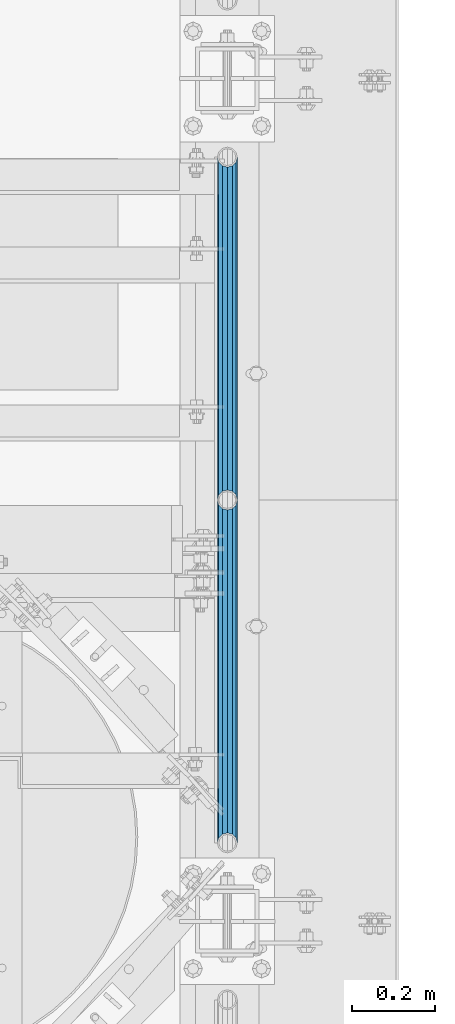
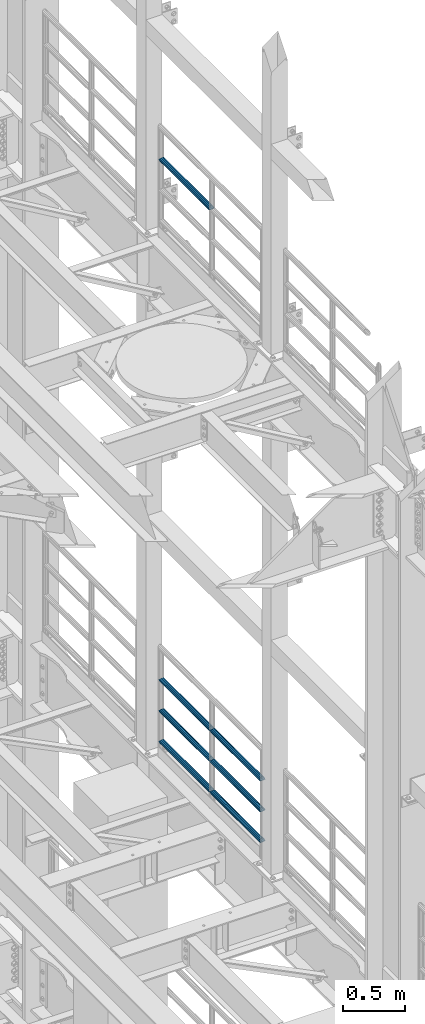
# One storey, part 1280 of 1876: 7 beams, 2 elements without a shape of their own.
"""IFC2X3 building model written with IfcOpenShell, lengths in millimetres."""

from ifc_helpers import new_model, si_unit, frame, origin_with_axes, place, context, subcontext, project, spatial, faceted_brep, material, type_object, element, aggregate, save


model = new_model("IFC2X3")

# Units and contexts
model_context = context("Model", 3, precision=1e-05, world=origin_with_axes())
body_context = subcontext(model_context, "Body", "Model", "MODEL_VIEW")
ifc_project = project(units=[si_unit("LENGTHUNIT", "METRE", prefix="MILLI"), si_unit("AREAUNIT", "SQUARE_METRE"), si_unit("VOLUMEUNIT", "CUBIC_METRE"), si_unit("MASSUNIT", "GRAM", prefix="KILO"), si_unit("TIMEUNIT", "SECOND"), si_unit("PLANEANGLEUNIT", "RADIAN"), si_unit("SOLIDANGLEUNIT", "STERADIAN"), si_unit("THERMODYNAMICTEMPERATUREUNIT", "DEGREE_CELSIUS"), si_unit("LUMINOUSINTENSITYUNIT", "LUMEN")], contexts=[model_context])

# Site, building, storey
site_placement = place(None, origin_with_axes())
site = spatial("IfcSite", under=ifc_project, at=site_placement, CompositionType="ELEMENT")
building_placement = place(site_placement, origin_with_axes())
building = spatial("IfcBuilding", under=site, at=building_placement, Name="Undefined", CompositionType="ELEMENT")
storey_placement = place(building_placement, origin_with_axes())
storey = spatial("IfcBuildingStorey", under=building, at=storey_placement, Name="Undefined", CompositionType="ELEMENT", Elevation=0.0)

# Assembly, beam
assembly_1_placement = place(storey_placement, origin_with_axes())
assembly_1 = element("IfcElementAssembly", 1, at=assembly_1_placement, inside=storey, Name="RAIL", AssemblyPlace="NOTDEFINED", PredefinedType="RIGID_FRAME")
ifc_material = material()
beam_type = type_object("IfcBeamType", Name="PIPE1-1/2SCH40", PredefinedType="NOTDEFINED")
beam_1_placement = place(assembly_1_placement, frame((7620.0, 4572.0, 14081.125), z_axis=(0.0, 0.0, -1.0), x_axis=(0.0, 1.0, 0.0)))
beam_1 = element("IfcBeam", 2, at=beam_1_placement, type_object=beam_type, material=ifc_material, Name="RAIL", ObjectType="PIPE1-1/2SCH40", context=body_context, shape_type="Brep", body=[
    faceted_brep([(0.0, 24.1299999999992, 0.0), (12.0650000000064, 20.8971929933177, -12.0649999999987), (12.0650000000064, 20.8971929933177, 12.0649999999987), (12.0650000000064, -20.8971929933177, 12.0649999999987), (12.0650000000064, -20.8971929933177, -12.0649999999987), (0.0, -24.1299999999992, 0.0), (20.8971929933249, -12.0650000000005, 20.8971929933177), (20.8971929933249, -12.0650000000005, 15.8661214311796), (15.2545715621445, -17.7076214311801, 10.2235000000001), (12.5151929933249, -20.4470000000001, 0.0), (15.2545715621445, -17.7076214311801, -10.2235000000001), (20.8971929933249, -12.0650000000005, -15.8661214311796), (20.8971929933249, -12.0650000000005, -20.8971929933177), (24.1300000000063, 0.0, -20.4470000000001), (24.1300000000063, 0.0, -24.130000000001), (21.3906214311868, -10.2235000000001, -17.7076214311819), (21.3906214311868, 10.2235000000001, -17.7076214311819), (20.8971929933249, 12.0650000000005, -15.8661214311796), (20.8971929933249, 12.0650000000005, -20.8971929933177), (15.2545715621445, 17.7076214311801, -10.2235000000001), (12.5151929933249, 20.4470000000001, 0.0), (15.2545715621445, 17.7076214311801, 10.2235000000001), (20.8971929933249, 12.0650000000005, 15.8661214311796), (20.8971929933249, 12.0650000000005, 20.8971929933177), (21.3906214311868, 10.2235000000001, 17.7076214311819), (24.1300000000064, 0.0, 20.4470000000001), (24.1300000000064, 0.0, 24.130000000001), (21.3906214311868, -10.2235000000001, 17.7076214311819), (826.77, 24.1300000000001, 0.0), (814.705, 20.8971929933186, -12.0649999999987), (805.872807006681, 12.0649999999996, -20.8971929933177), (826.77, -24.1300000000001, 0.0), (814.705, -20.8971929933186, -12.0649999999987), (814.705, -20.8971929933186, 12.0649999999987), (805.872807006681, -12.0649999999996, 20.8971929933177), (805.872807006681, -12.0649999999996, -20.8971929933177), (802.640000000001, 0.0, -24.130000000001), (805.379378568819, 10.2235000000001, -17.7076214311819), (802.640000000001, 0.0, -20.4470000000001), (805.872807006683, 12.0649999999996, -15.8661214311796), (805.872807006683, -12.0649999999996, -15.8661214311796), (805.379378568819, -10.2235000000001, -17.7076214311819), (811.515428437862, -17.7076214311801, -10.2235000000001), (814.254807006682, -20.4470000000001, 0.0), (811.515428437862, -17.7076214311801, 10.2235000000001), (805.872807006683, -12.0649999999996, 15.8661214311796), (805.379378568819, -10.2235000000001, 17.7076214311819), (802.640000000001, 0.0, 20.4470000000001), (802.640000000001, 0.0, 24.130000000001), (805.872807006681, 12.0649999999996, 20.8971929933177), (814.705, 20.8971929933186, 12.0649999999987), (805.872807006683, 12.0649999999996, 15.8661214311796), (811.515428437862, 17.7076214311801, 10.2235000000001), (814.254807006682, 20.4470000000001, 0.0), (811.515428437862, 17.7076214311801, -10.2235000000001), (805.379378568819, 10.2235000000001, 17.7076214311819)], [[[0, 1, 2]], [[3, 4, 5]], [[6, 7, 8, 9, 10, 11, 12, 4, 3]], [[13, 14, 12, 11, 15]], [[16, 17, 18, 14, 13]], [[2, 1, 18, 17, 19, 20, 21, 22, 23]], [[23, 22, 24, 25, 26]], [[26, 25, 27, 7, 6]], [[1, 0, 28, 29]], [[18, 1, 29, 30]], [[31, 32, 33]], [[6, 3, 33, 34]], [[3, 5, 31, 33]], [[5, 4, 32, 31]], [[4, 12, 35, 32]], [[12, 14, 36, 35]], [[14, 18, 30, 36]], [[37, 38, 36, 30, 39]], [[40, 35, 36, 38, 41]], [[33, 32, 35, 40, 42, 43, 44, 45, 34]], [[34, 45, 46, 47, 48]], [[26, 6, 34, 48]], [[2, 23, 49, 50]], [[23, 26, 48, 49]], [[0, 2, 50, 28]], [[28, 50, 29]], [[49, 51, 52, 53, 54, 39, 30, 29, 50]], [[48, 47, 55, 51, 49]], [[25, 24, 55, 47]], [[55, 24, 22, 21, 52, 51]], [[21, 20, 53, 52]], [[20, 19, 54, 53]], [[19, 17, 16, 37, 39, 54]], [[16, 13, 38, 37]], [[13, 15, 41, 38]], [[41, 15, 11, 10, 42, 40]], [[10, 9, 43, 42]], [[9, 8, 44, 43]], [[8, 7, 27, 46, 45, 44]], [[27, 25, 47, 46]]]),
])
aggregate(assembly_1, [beam_1])

# Assembly, beams
assembly_2_placement = place(storey_placement, origin_with_axes())
assembly_2 = element("IfcElementAssembly", 3, at=assembly_2_placement, inside=storey, Name="RAIL", AssemblyPlace="NOTDEFINED", PredefinedType="RIGID_FRAME")
beam_2_placement = place(assembly_2_placement, frame((7620.0, 4572.0, 8315.325), z_axis=(0.0, 0.0, 1.0), x_axis=(0.0, -1.0, 0.0)))
beam_2 = element("IfcBeam", 4, at=beam_2_placement, type_object=beam_type, material=ifc_material, Name="RAIL", ObjectType="PIPE1-1/2SCH40", context=body_context, shape_type="Brep", body=[
    faceted_brep([(805.872807006681, -12.0649999999996, 20.8971929933177), (805.872807006683, -12.0649999999996, 15.8661214311796), (805.379378568819, -10.2235000000001, 17.7076214311819), (802.640000000001, 0.0, 20.4470000000001), (802.640000000001, 0.0, 24.130000000001), (805.379378568819, 10.2235000000001, 17.7076214311819), (805.872807006683, 12.0649999999996, 15.8661214311796), (805.872807006681, 12.0649999999996, 20.8971929933177), (826.77, 24.1300000000001, 0.0), (814.705, 20.8971929933186, 12.0649999999987), (814.705, 20.8971929933186, -12.0649999999987), (811.515428437862, 17.7076214311801, 10.2235000000001), (814.254807006682, 20.4470000000001, 0.0), (811.515428437862, 17.7076214311801, -10.2235000000001), (805.872807006683, 12.0649999999996, -15.8661214311796), (805.872807006681, 12.0649999999996, -20.8971929933177), (805.379378568819, 10.2235000000001, -17.7076214311819), (802.640000000001, 0.0, -20.4470000000001), (802.640000000001, 0.0, -24.130000000001), (805.872807006683, -12.0649999999996, -15.8661214311796), (805.872807006681, -12.0649999999996, -20.8971929933177), (805.379378568819, -10.2235000000001, -17.7076214311819), (826.77, -24.1300000000001, 0.0), (814.705, -20.8971929933186, -12.0649999999987), (814.705, -20.8971929933186, 12.0649999999987), (811.515428437862, -17.7076214311801, -10.2235000000001), (814.254807006682, -20.4470000000001, 0.0), (811.515428437862, -17.7076214311801, 10.2235000000001), (12.0650000000064, -20.8971929933177, -12.0649999999987), (20.8971929933249, -12.0650000000005, -20.8971929933177), (0.0, 24.1299999999992, 0.0), (12.0650000000064, 20.8971929933177, -12.0649999999987), (12.0650000000064, 20.8971929933177, 12.0649999999987), (20.8971929933249, 12.0650000000005, 20.8971929933177), (24.1300000000064, 0.0, 24.130000000001), (20.8971929933249, 12.0650000000005, -20.8971929933177), (24.1300000000063, 0.0, -24.130000000001), (24.1300000000063, 0.0, -20.4470000000001), (20.8971929933249, -12.0650000000005, -15.8661214311796), (21.3906214311868, -10.2235000000001, -17.7076214311819), (21.3906214311868, 10.2235000000001, -17.7076214311819), (20.8971929933249, 12.0650000000005, -15.8661214311796), (15.2545715621445, 17.7076214311801, -10.2235000000001), (12.5151929933249, 20.4470000000001, 0.0), (15.2545715621445, 17.7076214311801, 10.2235000000001), (20.8971929933249, 12.0650000000005, 15.8661214311796), (21.3906214311868, 10.2235000000001, 17.7076214311819), (24.1300000000064, 0.0, 20.4470000000001), (21.3906214311868, -10.2235000000001, 17.7076214311819), (20.8971929933249, -12.0650000000005, 15.8661214311796), (20.8971929933249, -12.0650000000005, 20.8971929933177), (12.0650000000064, -20.8971929933177, 12.0649999999987), (0.0, -24.1299999999992, 0.0), (15.2545715621445, -17.7076214311801, 10.2235000000001), (12.5151929933249, -20.4470000000001, 0.0), (15.2545715621445, -17.7076214311801, -10.2235000000001)], [[[0, 1, 2, 3, 4]], [[4, 3, 5, 6, 7]], [[8, 9, 10]], [[7, 6, 11, 12, 13, 14, 15, 10, 9]], [[16, 17, 18, 15, 14]], [[19, 20, 18, 17, 21]], [[22, 23, 24]], [[24, 23, 20, 19, 25, 26, 27, 1, 0]], [[28, 29, 20, 23]], [[30, 31, 32]], [[33, 34, 4, 7]], [[32, 33, 7, 9]], [[30, 32, 9, 8]], [[31, 30, 8, 10]], [[35, 31, 10, 15]], [[36, 35, 15, 18]], [[29, 36, 18, 20]], [[37, 36, 29, 38, 39]], [[40, 41, 35, 36, 37]], [[32, 31, 35, 41, 42, 43, 44, 45, 33]], [[33, 45, 46, 47, 34]], [[34, 47, 48, 49, 50]], [[34, 50, 0, 4]], [[50, 51, 24, 0]], [[51, 52, 22, 24]], [[52, 28, 23, 22]], [[51, 28, 52]], [[50, 49, 53, 54, 55, 38, 29, 28, 51]], [[55, 54, 26, 25]], [[21, 39, 38, 55, 25, 19]], [[37, 39, 21, 17]], [[40, 37, 17, 16]], [[42, 41, 40, 16, 14, 13]], [[43, 42, 13, 12]], [[44, 43, 12, 11]], [[5, 46, 45, 44, 11, 6]], [[47, 46, 5, 3]], [[48, 47, 3, 2]], [[53, 49, 48, 2, 1, 27]], [[54, 53, 27, 26]]]),
])
beam_3_placement = place(assembly_2_placement, frame((7620.0, 5398.77, 8315.325), z_axis=(0.0, 0.0, 1.0), x_axis=(0.0, -1.0, 0.0)))
beam_3 = element("IfcBeam", 5, at=beam_3_placement, type_object=beam_type, material=ifc_material, Name="RAIL", ObjectType="PIPE1-1/2SCH40", context=body_context, shape_type="Brep", body=[
    faceted_brep([(805.872807006681, -12.0649999999996, 20.8971929933177), (805.872807006683, -12.0649999999996, 15.8661214311796), (805.379378568819, -10.2235000000001, 17.7076214311819), (802.640000000001, 0.0, 20.4470000000001), (802.640000000001, 0.0, 24.130000000001), (805.379378568819, 10.2235000000001, 17.7076214311819), (805.872807006683, 12.0649999999996, 15.8661214311796), (805.872807006681, 12.0649999999996, 20.8971929933177), (826.77, 24.1300000000001, 0.0), (814.705, 20.8971929933186, 12.0649999999987), (814.705, 20.8971929933186, -12.0649999999987), (811.515428437862, 17.7076214311801, 10.2235000000001), (814.254807006682, 20.4470000000001, 0.0), (811.515428437862, 17.7076214311801, -10.2235000000001), (805.872807006683, 12.0649999999996, -15.8661214311796), (805.872807006681, 12.0649999999996, -20.8971929933177), (805.379378568819, 10.2235000000001, -17.7076214311819), (802.640000000001, 0.0, -20.4470000000001), (802.640000000001, 0.0, -24.130000000001), (805.872807006683, -12.0649999999996, -15.8661214311796), (805.872807006681, -12.0649999999996, -20.8971929933177), (805.379378568819, -10.2235000000001, -17.7076214311819), (826.77, -24.1300000000001, 0.0), (814.705, -20.8971929933186, -12.0649999999987), (814.705, -20.8971929933186, 12.0649999999987), (811.515428437862, -17.7076214311801, -10.2235000000001), (814.254807006682, -20.4470000000001, 0.0), (811.515428437862, -17.7076214311801, 10.2235000000001), (12.0650000000064, -20.8971929933177, -12.0649999999987), (20.8971929933249, -12.0650000000005, -20.8971929933177), (0.0, 24.1299999999992, 0.0), (12.0650000000064, 20.8971929933177, -12.0649999999987), (12.0650000000064, 20.8971929933177, 12.0649999999987), (20.8971929933249, 12.0650000000005, 20.8971929933177), (24.1300000000064, 0.0, 24.130000000001), (20.8971929933249, 12.0650000000005, -20.8971929933177), (24.1300000000063, 0.0, -24.130000000001), (24.1300000000063, 0.0, -20.4470000000001), (20.8971929933249, -12.0650000000005, -15.8661214311796), (21.3906214311868, -10.2235000000001, -17.7076214311819), (21.3906214311868, 10.2235000000001, -17.7076214311819), (20.8971929933249, 12.0650000000005, -15.8661214311796), (15.2545715621445, 17.7076214311801, -10.2235000000001), (12.5151929933249, 20.4470000000001, 0.0), (15.2545715621445, 17.7076214311801, 10.2235000000001), (20.8971929933249, 12.0650000000005, 15.8661214311796), (21.3906214311868, 10.2235000000001, 17.7076214311819), (24.1300000000064, 0.0, 20.4470000000001), (21.3906214311868, -10.2235000000001, 17.7076214311819), (20.8971929933249, -12.0650000000005, 15.8661214311796), (20.8971929933249, -12.0650000000005, 20.8971929933177), (12.0650000000064, -20.8971929933177, 12.0649999999987), (0.0, -24.1299999999992, 0.0), (15.2545715621445, -17.7076214311801, 10.2235000000001), (12.5151929933249, -20.4470000000001, 0.0), (15.2545715621445, -17.7076214311801, -10.2235000000001)], [[[0, 1, 2, 3, 4]], [[4, 3, 5, 6, 7]], [[8, 9, 10]], [[7, 6, 11, 12, 13, 14, 15, 10, 9]], [[16, 17, 18, 15, 14]], [[19, 20, 18, 17, 21]], [[22, 23, 24]], [[24, 23, 20, 19, 25, 26, 27, 1, 0]], [[28, 29, 20, 23]], [[30, 31, 32]], [[33, 34, 4, 7]], [[32, 33, 7, 9]], [[30, 32, 9, 8]], [[31, 30, 8, 10]], [[35, 31, 10, 15]], [[36, 35, 15, 18]], [[29, 36, 18, 20]], [[37, 36, 29, 38, 39]], [[40, 41, 35, 36, 37]], [[32, 31, 35, 41, 42, 43, 44, 45, 33]], [[33, 45, 46, 47, 34]], [[34, 47, 48, 49, 50]], [[34, 50, 0, 4]], [[50, 51, 24, 0]], [[51, 52, 22, 24]], [[52, 28, 23, 22]], [[51, 28, 52]], [[50, 49, 53, 54, 55, 38, 29, 28, 51]], [[55, 54, 26, 25]], [[21, 39, 38, 55, 25, 19]], [[37, 39, 21, 17]], [[40, 37, 17, 16]], [[42, 41, 40, 16, 14, 13]], [[43, 42, 13, 12]], [[44, 43, 12, 11]], [[5, 46, 45, 44, 11, 6]], [[47, 46, 5, 3]], [[48, 47, 3, 2]], [[53, 49, 48, 2, 1, 27]], [[54, 53, 27, 26]]]),
])
beam_4_placement = place(assembly_2_placement, frame((7620.0, 3745.23, 8620.125), z_axis=(0.0, 0.0, -1.0), x_axis=(0.0, 1.0, 0.0)))
beam_4 = element("IfcBeam", 6, at=beam_4_placement, type_object=beam_type, material=ifc_material, Name="RAIL", ObjectType="PIPE1-1/2SCH40", context=body_context, shape_type="Brep", body=[
    faceted_brep([(0.0, 24.1299999999992, 0.0), (12.0650000000064, 20.8971929933177, -12.0649999999987), (12.0650000000064, 20.8971929933177, 12.0649999999987), (12.0650000000064, -20.8971929933177, 12.0649999999987), (12.0650000000064, -20.8971929933177, -12.0649999999987), (0.0, -24.1299999999992, 0.0), (20.8971929933249, -12.0650000000005, 20.8971929933177), (20.8971929933249, -12.0650000000005, 15.8661214311796), (15.2545715621445, -17.7076214311801, 10.2235000000001), (12.5151929933249, -20.4470000000001, 0.0), (15.2545715621445, -17.7076214311801, -10.2235000000001), (20.8971929933249, -12.0650000000005, -15.8661214311796), (20.8971929933249, -12.0650000000005, -20.8971929933177), (24.1300000000063, 0.0, -20.4470000000001), (24.1300000000063, 0.0, -24.130000000001), (21.3906214311868, -10.2235000000001, -17.7076214311819), (21.3906214311868, 10.2235000000001, -17.7076214311819), (20.8971929933249, 12.0650000000005, -15.8661214311796), (20.8971929933249, 12.0650000000005, -20.8971929933177), (15.2545715621445, 17.7076214311801, -10.2235000000001), (12.5151929933249, 20.4470000000001, 0.0), (15.2545715621445, 17.7076214311801, 10.2235000000001), (20.8971929933249, 12.0650000000005, 15.8661214311796), (20.8971929933249, 12.0650000000005, 20.8971929933177), (21.3906214311868, 10.2235000000001, 17.7076214311819), (24.1300000000064, 0.0, 20.4470000000001), (24.1300000000064, 0.0, 24.130000000001), (21.3906214311868, -10.2235000000001, 17.7076214311819), (826.77, 24.1300000000001, 0.0), (814.705, 20.8971929933186, -12.0649999999987), (805.872807006681, 12.0649999999996, -20.8971929933177), (826.77, -24.1300000000001, 0.0), (814.705, -20.8971929933186, -12.0649999999987), (814.705, -20.8971929933186, 12.0649999999987), (805.872807006681, -12.0649999999996, 20.8971929933177), (805.872807006681, -12.0649999999996, -20.8971929933177), (802.640000000001, 0.0, -24.130000000001), (805.379378568819, 10.2235000000001, -17.7076214311819), (802.640000000001, 0.0, -20.4470000000001), (805.872807006683, 12.0649999999996, -15.8661214311796), (805.872807006683, -12.0649999999996, -15.8661214311796), (805.379378568819, -10.2235000000001, -17.7076214311819), (811.515428437862, -17.7076214311801, -10.2235000000001), (814.254807006682, -20.4470000000001, 0.0), (811.515428437862, -17.7076214311801, 10.2235000000001), (805.872807006683, -12.0649999999996, 15.8661214311796), (805.379378568819, -10.2235000000001, 17.7076214311819), (802.640000000001, 0.0, 20.4470000000001), (802.640000000001, 0.0, 24.130000000001), (805.872807006681, 12.0649999999996, 20.8971929933177), (814.705, 20.8971929933186, 12.0649999999987), (805.872807006683, 12.0649999999996, 15.8661214311796), (811.515428437862, 17.7076214311801, 10.2235000000001), (814.254807006682, 20.4470000000001, 0.0), (811.515428437862, 17.7076214311801, -10.2235000000001), (805.379378568819, 10.2235000000001, 17.7076214311819)], [[[0, 1, 2]], [[3, 4, 5]], [[6, 7, 8, 9, 10, 11, 12, 4, 3]], [[13, 14, 12, 11, 15]], [[16, 17, 18, 14, 13]], [[2, 1, 18, 17, 19, 20, 21, 22, 23]], [[23, 22, 24, 25, 26]], [[26, 25, 27, 7, 6]], [[1, 0, 28, 29]], [[18, 1, 29, 30]], [[31, 32, 33]], [[6, 3, 33, 34]], [[3, 5, 31, 33]], [[5, 4, 32, 31]], [[4, 12, 35, 32]], [[12, 14, 36, 35]], [[14, 18, 30, 36]], [[37, 38, 36, 30, 39]], [[40, 35, 36, 38, 41]], [[33, 32, 35, 40, 42, 43, 44, 45, 34]], [[34, 45, 46, 47, 48]], [[26, 6, 34, 48]], [[2, 23, 49, 50]], [[23, 26, 48, 49]], [[0, 2, 50, 28]], [[28, 50, 29]], [[49, 51, 52, 53, 54, 39, 30, 29, 50]], [[48, 47, 55, 51, 49]], [[25, 24, 55, 47]], [[55, 24, 22, 21, 52, 51]], [[21, 20, 53, 52]], [[20, 19, 54, 53]], [[19, 17, 16, 37, 39, 54]], [[16, 13, 38, 37]], [[13, 15, 41, 38]], [[41, 15, 11, 10, 42, 40]], [[10, 9, 43, 42]], [[9, 8, 44, 43]], [[8, 7, 27, 46, 45, 44]], [[27, 25, 47, 46]]]),
])
beam_5_placement = place(assembly_2_placement, frame((7620.0, 4572.0, 8620.125), z_axis=(0.0, 0.0, -1.0), x_axis=(0.0, 1.0, 0.0)))
beam_5 = element("IfcBeam", 7, at=beam_5_placement, type_object=beam_type, material=ifc_material, Name="RAIL", ObjectType="PIPE1-1/2SCH40", context=body_context, shape_type="Brep", body=[
    faceted_brep([(0.0, 24.1299999999992, 0.0), (12.0650000000064, 20.8971929933177, -12.0649999999987), (12.0650000000064, 20.8971929933177, 12.0649999999987), (12.0650000000064, -20.8971929933177, 12.0649999999987), (12.0650000000064, -20.8971929933177, -12.0649999999987), (0.0, -24.1299999999992, 0.0), (20.8971929933249, -12.0650000000005, 20.8971929933177), (20.8971929933249, -12.0650000000005, 15.8661214311796), (15.2545715621445, -17.7076214311801, 10.2235000000001), (12.5151929933249, -20.4470000000001, 0.0), (15.2545715621445, -17.7076214311801, -10.2235000000001), (20.8971929933249, -12.0650000000005, -15.8661214311796), (20.8971929933249, -12.0650000000005, -20.8971929933177), (24.1300000000063, 0.0, -20.4470000000001), (24.1300000000063, 0.0, -24.130000000001), (21.3906214311868, -10.2235000000001, -17.7076214311819), (21.3906214311868, 10.2235000000001, -17.7076214311819), (20.8971929933249, 12.0650000000005, -15.8661214311796), (20.8971929933249, 12.0650000000005, -20.8971929933177), (15.2545715621445, 17.7076214311801, -10.2235000000001), (12.5151929933249, 20.4470000000001, 0.0), (15.2545715621445, 17.7076214311801, 10.2235000000001), (20.8971929933249, 12.0650000000005, 15.8661214311796), (20.8971929933249, 12.0650000000005, 20.8971929933177), (21.3906214311868, 10.2235000000001, 17.7076214311819), (24.1300000000064, 0.0, 20.4470000000001), (24.1300000000064, 0.0, 24.130000000001), (21.3906214311868, -10.2235000000001, 17.7076214311819), (826.77, 24.1300000000001, 0.0), (814.705, 20.8971929933186, -12.0649999999987), (805.872807006681, 12.0649999999996, -20.8971929933177), (826.77, -24.1300000000001, 0.0), (814.705, -20.8971929933186, -12.0649999999987), (814.705, -20.8971929933186, 12.0649999999987), (805.872807006681, -12.0649999999996, 20.8971929933177), (805.872807006681, -12.0649999999996, -20.8971929933177), (802.640000000001, 0.0, -24.130000000001), (805.379378568819, 10.2235000000001, -17.7076214311819), (802.640000000001, 0.0, -20.4470000000001), (805.872807006683, 12.0649999999996, -15.8661214311796), (805.872807006683, -12.0649999999996, -15.8661214311796), (805.379378568819, -10.2235000000001, -17.7076214311819), (811.515428437862, -17.7076214311801, -10.2235000000001), (814.254807006682, -20.4470000000001, 0.0), (811.515428437862, -17.7076214311801, 10.2235000000001), (805.872807006683, -12.0649999999996, 15.8661214311796), (805.379378568819, -10.2235000000001, 17.7076214311819), (802.640000000001, 0.0, 20.4470000000001), (802.640000000001, 0.0, 24.130000000001), (805.872807006681, 12.0649999999996, 20.8971929933177), (814.705, 20.8971929933186, 12.0649999999987), (805.872807006683, 12.0649999999996, 15.8661214311796), (811.515428437862, 17.7076214311801, 10.2235000000001), (814.254807006682, 20.4470000000001, 0.0), (811.515428437862, 17.7076214311801, -10.2235000000001), (805.379378568819, 10.2235000000001, 17.7076214311819)], [[[0, 1, 2]], [[3, 4, 5]], [[6, 7, 8, 9, 10, 11, 12, 4, 3]], [[13, 14, 12, 11, 15]], [[16, 17, 18, 14, 13]], [[2, 1, 18, 17, 19, 20, 21, 22, 23]], [[23, 22, 24, 25, 26]], [[26, 25, 27, 7, 6]], [[1, 0, 28, 29]], [[18, 1, 29, 30]], [[31, 32, 33]], [[6, 3, 33, 34]], [[3, 5, 31, 33]], [[5, 4, 32, 31]], [[4, 12, 35, 32]], [[12, 14, 36, 35]], [[14, 18, 30, 36]], [[37, 38, 36, 30, 39]], [[40, 35, 36, 38, 41]], [[33, 32, 35, 40, 42, 43, 44, 45, 34]], [[34, 45, 46, 47, 48]], [[26, 6, 34, 48]], [[2, 23, 49, 50]], [[23, 26, 48, 49]], [[0, 2, 50, 28]], [[28, 50, 29]], [[49, 51, 52, 53, 54, 39, 30, 29, 50]], [[48, 47, 55, 51, 49]], [[25, 24, 55, 47]], [[55, 24, 22, 21, 52, 51]], [[21, 20, 53, 52]], [[20, 19, 54, 53]], [[19, 17, 16, 37, 39, 54]], [[16, 13, 38, 37]], [[13, 15, 41, 38]], [[41, 15, 11, 10, 42, 40]], [[10, 9, 43, 42]], [[9, 8, 44, 43]], [[8, 7, 27, 46, 45, 44]], [[27, 25, 47, 46]]]),
])
beam_6_placement = place(assembly_2_placement, frame((7620.0, 3745.23, 8924.925), z_axis=(0.0, 0.0, -1.0), x_axis=(0.0, 1.0, 0.0)))
beam_6 = element("IfcBeam", 8, at=beam_6_placement, type_object=beam_type, material=ifc_material, Name="RAIL", ObjectType="PIPE1-1/2SCH40", context=body_context, shape_type="Brep", body=[
    faceted_brep([(0.0, 24.1299999999992, 0.0), (12.0650000000064, 20.8971929933177, -12.0649999999987), (12.0650000000064, 20.8971929933177, 12.0649999999987), (12.0650000000064, -20.8971929933177, 12.0649999999987), (12.0650000000064, -20.8971929933177, -12.0649999999987), (0.0, -24.1299999999992, 0.0), (20.8971929933249, -12.0650000000005, 20.8971929933177), (20.8971929933249, -12.0650000000005, 15.8661214311796), (15.2545715621445, -17.7076214311801, 10.2235000000001), (12.5151929933249, -20.4470000000001, 0.0), (15.2545715621445, -17.7076214311801, -10.2235000000001), (20.8971929933249, -12.0650000000005, -15.8661214311796), (20.8971929933249, -12.0650000000005, -20.8971929933177), (24.1300000000063, 0.0, -20.4470000000001), (24.1300000000063, 0.0, -24.130000000001), (21.3906214311868, -10.2235000000001, -17.7076214311819), (21.3906214311868, 10.2235000000001, -17.7076214311819), (20.8971929933249, 12.0650000000005, -15.8661214311796), (20.8971929933249, 12.0650000000005, -20.8971929933177), (15.2545715621445, 17.7076214311801, -10.2235000000001), (12.5151929933249, 20.4470000000001, 0.0), (15.2545715621445, 17.7076214311801, 10.2235000000001), (20.8971929933249, 12.0650000000005, 15.8661214311796), (20.8971929933249, 12.0650000000005, 20.8971929933177), (21.3906214311868, 10.2235000000001, 17.7076214311819), (24.1300000000064, 0.0, 20.4470000000001), (24.1300000000064, 0.0, 24.130000000001), (21.3906214311868, -10.2235000000001, 17.7076214311819), (826.77, 24.1300000000001, 0.0), (814.705, 20.8971929933186, -12.0649999999987), (805.872807006681, 12.0649999999996, -20.8971929933177), (826.77, -24.1300000000001, 0.0), (814.705, -20.8971929933186, -12.0649999999987), (814.705, -20.8971929933186, 12.0649999999987), (805.872807006681, -12.0649999999996, 20.8971929933177), (805.872807006681, -12.0649999999996, -20.8971929933177), (802.640000000001, 0.0, -24.130000000001), (805.379378568819, 10.2235000000001, -17.7076214311819), (802.640000000001, 0.0, -20.4470000000001), (805.872807006683, 12.0649999999996, -15.8661214311796), (805.872807006683, -12.0649999999996, -15.8661214311796), (805.379378568819, -10.2235000000001, -17.7076214311819), (811.515428437862, -17.7076214311801, -10.2235000000001), (814.254807006682, -20.4470000000001, 0.0), (811.515428437862, -17.7076214311801, 10.2235000000001), (805.872807006683, -12.0649999999996, 15.8661214311796), (805.379378568819, -10.2235000000001, 17.7076214311819), (802.640000000001, 0.0, 20.4470000000001), (802.640000000001, 0.0, 24.130000000001), (805.872807006681, 12.0649999999996, 20.8971929933177), (814.705, 20.8971929933186, 12.0649999999987), (805.872807006683, 12.0649999999996, 15.8661214311796), (811.515428437862, 17.7076214311801, 10.2235000000001), (814.254807006682, 20.4470000000001, 0.0), (811.515428437862, 17.7076214311801, -10.2235000000001), (805.379378568819, 10.2235000000001, 17.7076214311819)], [[[0, 1, 2]], [[3, 4, 5]], [[6, 7, 8, 9, 10, 11, 12, 4, 3]], [[13, 14, 12, 11, 15]], [[16, 17, 18, 14, 13]], [[2, 1, 18, 17, 19, 20, 21, 22, 23]], [[23, 22, 24, 25, 26]], [[26, 25, 27, 7, 6]], [[1, 0, 28, 29]], [[18, 1, 29, 30]], [[31, 32, 33]], [[6, 3, 33, 34]], [[3, 5, 31, 33]], [[5, 4, 32, 31]], [[4, 12, 35, 32]], [[12, 14, 36, 35]], [[14, 18, 30, 36]], [[37, 38, 36, 30, 39]], [[40, 35, 36, 38, 41]], [[33, 32, 35, 40, 42, 43, 44, 45, 34]], [[34, 45, 46, 47, 48]], [[26, 6, 34, 48]], [[2, 23, 49, 50]], [[23, 26, 48, 49]], [[0, 2, 50, 28]], [[28, 50, 29]], [[49, 51, 52, 53, 54, 39, 30, 29, 50]], [[48, 47, 55, 51, 49]], [[25, 24, 55, 47]], [[55, 24, 22, 21, 52, 51]], [[21, 20, 53, 52]], [[20, 19, 54, 53]], [[19, 17, 16, 37, 39, 54]], [[16, 13, 38, 37]], [[13, 15, 41, 38]], [[41, 15, 11, 10, 42, 40]], [[10, 9, 43, 42]], [[9, 8, 44, 43]], [[8, 7, 27, 46, 45, 44]], [[27, 25, 47, 46]]]),
])
beam_7_placement = place(assembly_2_placement, frame((7620.0, 4572.0, 8924.925), z_axis=(0.0, 0.0, -1.0), x_axis=(0.0, 1.0, 0.0)))
beam_7 = element("IfcBeam", 9, at=beam_7_placement, type_object=beam_type, material=ifc_material, Name="RAIL", ObjectType="PIPE1-1/2SCH40", context=body_context, shape_type="Brep", body=[
    faceted_brep([(0.0, 24.1299999999992, 0.0), (12.0650000000064, 20.8971929933177, -12.0649999999987), (12.0650000000064, 20.8971929933177, 12.0649999999987), (12.0650000000064, -20.8971929933177, 12.0649999999987), (12.0650000000064, -20.8971929933177, -12.0649999999987), (0.0, -24.1299999999992, 0.0), (20.8971929933249, -12.0650000000005, 20.8971929933177), (20.8971929933249, -12.0650000000005, 15.8661214311796), (15.2545715621445, -17.7076214311801, 10.2235000000001), (12.5151929933249, -20.4470000000001, 0.0), (15.2545715621445, -17.7076214311801, -10.2235000000001), (20.8971929933249, -12.0650000000005, -15.8661214311796), (20.8971929933249, -12.0650000000005, -20.8971929933177), (24.1300000000063, 0.0, -20.4470000000001), (24.1300000000063, 0.0, -24.130000000001), (21.3906214311868, -10.2235000000001, -17.7076214311819), (21.3906214311868, 10.2235000000001, -17.7076214311819), (20.8971929933249, 12.0650000000005, -15.8661214311796), (20.8971929933249, 12.0650000000005, -20.8971929933177), (15.2545715621445, 17.7076214311801, -10.2235000000001), (12.5151929933249, 20.4470000000001, 0.0), (15.2545715621445, 17.7076214311801, 10.2235000000001), (20.8971929933249, 12.0650000000005, 15.8661214311796), (20.8971929933249, 12.0650000000005, 20.8971929933177), (21.3906214311868, 10.2235000000001, 17.7076214311819), (24.1300000000064, 0.0, 20.4470000000001), (24.1300000000064, 0.0, 24.130000000001), (21.3906214311868, -10.2235000000001, 17.7076214311819), (826.77, 24.1300000000001, 0.0), (814.705, 20.8971929933186, -12.0649999999987), (805.872807006681, 12.0649999999996, -20.8971929933177), (826.77, -24.1300000000001, 0.0), (814.705, -20.8971929933186, -12.0649999999987), (814.705, -20.8971929933186, 12.0649999999987), (805.872807006681, -12.0649999999996, 20.8971929933177), (805.872807006681, -12.0649999999996, -20.8971929933177), (802.640000000001, 0.0, -24.130000000001), (805.379378568819, 10.2235000000001, -17.7076214311819), (802.640000000001, 0.0, -20.4470000000001), (805.872807006683, 12.0649999999996, -15.8661214311796), (805.872807006683, -12.0649999999996, -15.8661214311796), (805.379378568819, -10.2235000000001, -17.7076214311819), (811.515428437862, -17.7076214311801, -10.2235000000001), (814.254807006682, -20.4470000000001, 0.0), (811.515428437862, -17.7076214311801, 10.2235000000001), (805.872807006683, -12.0649999999996, 15.8661214311796), (805.379378568819, -10.2235000000001, 17.7076214311819), (802.640000000001, 0.0, 20.4470000000001), (802.640000000001, 0.0, 24.130000000001), (805.872807006681, 12.0649999999996, 20.8971929933177), (814.705, 20.8971929933186, 12.0649999999987), (805.872807006683, 12.0649999999996, 15.8661214311796), (811.515428437862, 17.7076214311801, 10.2235000000001), (814.254807006682, 20.4470000000001, 0.0), (811.515428437862, 17.7076214311801, -10.2235000000001), (805.379378568819, 10.2235000000001, 17.7076214311819)], [[[0, 1, 2]], [[3, 4, 5]], [[6, 7, 8, 9, 10, 11, 12, 4, 3]], [[13, 14, 12, 11, 15]], [[16, 17, 18, 14, 13]], [[2, 1, 18, 17, 19, 20, 21, 22, 23]], [[23, 22, 24, 25, 26]], [[26, 25, 27, 7, 6]], [[1, 0, 28, 29]], [[18, 1, 29, 30]], [[31, 32, 33]], [[6, 3, 33, 34]], [[3, 5, 31, 33]], [[5, 4, 32, 31]], [[4, 12, 35, 32]], [[12, 14, 36, 35]], [[14, 18, 30, 36]], [[37, 38, 36, 30, 39]], [[40, 35, 36, 38, 41]], [[33, 32, 35, 40, 42, 43, 44, 45, 34]], [[34, 45, 46, 47, 48]], [[26, 6, 34, 48]], [[2, 23, 49, 50]], [[23, 26, 48, 49]], [[0, 2, 50, 28]], [[28, 50, 29]], [[49, 51, 52, 53, 54, 39, 30, 29, 50]], [[48, 47, 55, 51, 49]], [[25, 24, 55, 47]], [[55, 24, 22, 21, 52, 51]], [[21, 20, 53, 52]], [[20, 19, 54, 53]], [[19, 17, 16, 37, 39, 54]], [[16, 13, 38, 37]], [[13, 15, 41, 38]], [[41, 15, 11, 10, 42, 40]], [[10, 9, 43, 42]], [[9, 8, 44, 43]], [[8, 7, 27, 46, 45, 44]], [[27, 25, 47, 46]]]),
])
aggregate(assembly_2, [beam_2, beam_3, beam_4, beam_5, beam_6, beam_7])

save(model, "model.ifc")
